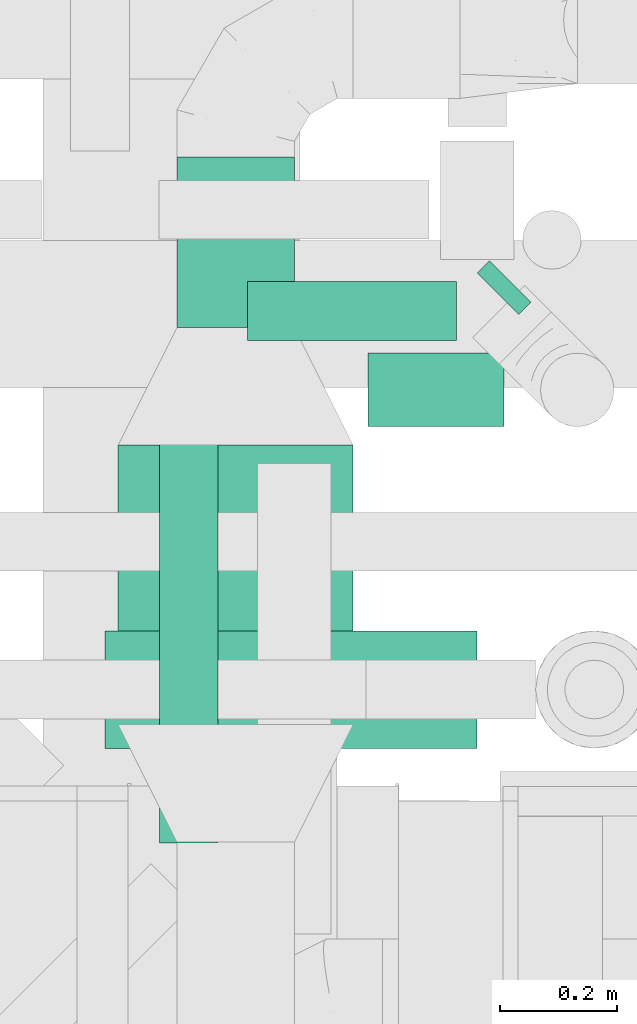
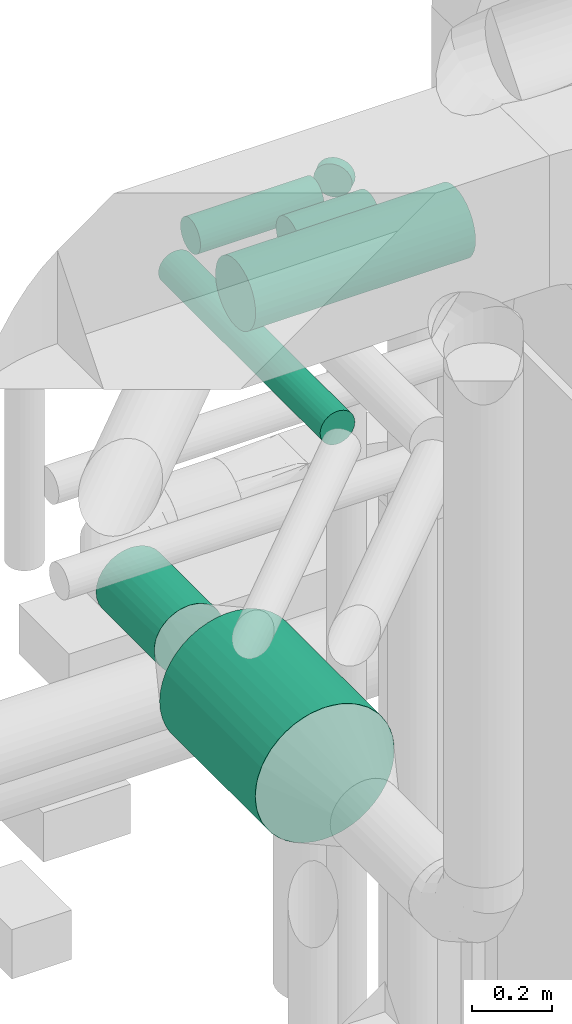
# One storey, part 249 of 337: 7 flow segments.
"""IFC2X3 building model written with IfcOpenShell, lengths in millimetres."""

from ifc_helpers import new_model, entity, si_unit, converted_unit, derived_unit, direction, frame, origin, origin_2d_with_axis, place, context, subcontext, project, spatial, circle, extrude, type_object, element, save


model = new_model("IFC2X3")

# Units and contexts
model_context = context("Model", 3, precision=0.01, world=origin(), true_north=direction((6.12303176911189e-17, 1.0)))
body_context = subcontext(model_context, "Body", "Model", "MODEL_VIEW")
ifc_project = project(units=[si_unit("LENGTHUNIT", "METRE", prefix="MILLI"), si_unit("AREAUNIT", "SQUARE_METRE"), si_unit("VOLUMEUNIT", "CUBIC_METRE"), converted_unit("PLANEANGLEUNIT", "DEGREE", entity("IfcRatioMeasure", 0.0174532925199433), si_unit("PLANEANGLEUNIT", "RADIAN"), dimensions=[0, 0, 0, 0, 0, 0, 0]), si_unit("MASSUNIT", "GRAM", prefix="KILO"), derived_unit("MASSDENSITYUNIT", [(si_unit("MASSUNIT", "GRAM", prefix="KILO"), 1), (si_unit("LENGTHUNIT", "METRE"), -3)]), derived_unit("MOMENTOFINERTIAUNIT", [(si_unit("LENGTHUNIT", "METRE"), 4)]), si_unit("TIMEUNIT", "SECOND"), si_unit("FREQUENCYUNIT", "HERTZ"), si_unit("THERMODYNAMICTEMPERATUREUNIT", "DEGREE_CELSIUS"), derived_unit("THERMALTRANSMITTANCEUNIT", [(si_unit("MASSUNIT", "GRAM", prefix="KILO"), 1), (si_unit("THERMODYNAMICTEMPERATUREUNIT", "KELVIN"), -1), (si_unit("TIMEUNIT", "SECOND"), -3)]), derived_unit("VOLUMETRICFLOWRATEUNIT", [(si_unit("LENGTHUNIT", "METRE"), 3), (si_unit("TIMEUNIT", "SECOND"), -1)]), derived_unit("MASSFLOWRATEUNIT", [(si_unit("MASSUNIT", "GRAM", prefix="KILO"), 1), (si_unit("TIMEUNIT", "SECOND"), -1)]), derived_unit("ROTATIONALFREQUENCYUNIT", [(si_unit("TIMEUNIT", "SECOND"), -1)]), si_unit("ELECTRICCURRENTUNIT", "AMPERE"), si_unit("ELECTRICVOLTAGEUNIT", "VOLT"), si_unit("POWERUNIT", "WATT"), si_unit("FORCEUNIT", "NEWTON", prefix="KILO"), si_unit("ILLUMINANCEUNIT", "LUX"), si_unit("LUMINOUSFLUXUNIT", "LUMEN"), si_unit("LUMINOUSINTENSITYUNIT", "CANDELA"), derived_unit("USERDEFINED", [(si_unit("MASSUNIT", "GRAM", prefix="KILO"), -1), (si_unit("LENGTHUNIT", "METRE"), -2), (si_unit("TIMEUNIT", "SECOND"), 3), (si_unit("LUMINOUSFLUXUNIT", "LUMEN"), 1)]), derived_unit("LINEARVELOCITYUNIT", [(si_unit("LENGTHUNIT", "METRE"), 1), (si_unit("TIMEUNIT", "SECOND"), -1)]), si_unit("PRESSUREUNIT", "PASCAL"), derived_unit("USERDEFINED", [(si_unit("LENGTHUNIT", "METRE"), -2), (si_unit("MASSUNIT", "GRAM", prefix="KILO"), 1), (si_unit("TIMEUNIT", "SECOND"), -2)]), derived_unit("LINEARFORCEUNIT", [(si_unit("MASSUNIT", "GRAM", prefix="KILO"), 1), (si_unit("LENGTHUNIT", "METRE"), 1), (si_unit("TIMEUNIT", "SECOND"), -2), (si_unit("LENGTHUNIT", "METRE"), -1)]), derived_unit("PLANARFORCEUNIT", [(si_unit("MASSUNIT", "GRAM", prefix="KILO"), 1), (si_unit("LENGTHUNIT", "METRE"), 1), (si_unit("TIMEUNIT", "SECOND"), -2), (si_unit("LENGTHUNIT", "METRE"), -2)])], contexts=[model_context])

# Site, building, storey
site_placement = place(None, origin())
site = spatial("IfcSite", under=ifc_project, at=site_placement, CompositionType="ELEMENT")
building_placement = place(site_placement, origin())
building = spatial("IfcBuilding", under=site, at=building_placement, CompositionType="ELEMENT")
storey_placement = place(building_placement, origin())
storey = spatial("IfcBuildingStorey", under=building, at=storey_placement, CompositionType="ELEMENT", Elevation=0.0)

# Flow segments
duct_segment_type = type_object("IfcDuctSegmentType", PredefinedType="NOTDEFINED")
flow_segment_1_placement = place(storey_placement, frame((58173.85, 11593.18, 30448.4)))
element("IfcFlowSegment", 1, at=flow_segment_1_placement, inside=storey, type_object=duct_segment_type, context=body_context, shape_type="SweptSolid", body=[
    extrude(circle(Radius=50.0, at=origin_2d_with_axis()), frame((51.6, 0.0, 51.6), z_axis=(0.0, 1.0, 0.0), x_axis=(1.0, 0.0, 0.0)), (0.0, 0.0, 1.0), 805.319830735413),
])
flow_segment_2_placement = place(storey_placement, frame((58325.44, 12446.9, 30448.4)))
element("IfcFlowSegment", 2, at=flow_segment_2_placement, inside=storey, type_object=duct_segment_type, context=body_context, shape_type="SweptSolid", body=[
    extrude(circle(Radius=50.0, at=origin_2d_with_axis()), frame((0.0, 51.6, 51.6), z_axis=(1.0, 0.0, 0.0), x_axis=(0.0, -1.0, 0.0)), (0.0, 0.0, 1.0), 355.473090735392),
])
flow_segment_3_placement = place(storey_placement, frame((58714.68, 12490.84, 30448.4)))
element("IfcFlowSegment", 3, at=flow_segment_3_placement, inside=storey, type_object=duct_segment_type, context=body_context, shape_type="SweptSolid", body=[
    extrude(circle(Radius=50.0, at=origin_2d_with_axis()), frame((36.95, 36.95, 51.6), z_axis=(0.707106781186548, 0.707106781186548, 0.0), x_axis=(0.707106781186548, -0.707106781186548, 0.0)), (0.0, 0.0, 1.0), 30.0134160280934),
])
flow_segment_4_placement = place(storey_placement, frame((58530.03, 12300.23, 30433.4)))
element("IfcFlowSegment", 4, at=flow_segment_4_placement, inside=storey, type_object=duct_segment_type, context=body_context, shape_type="SweptSolid", body=[
    extrude(circle(Radius=62.5, at=origin_2d_with_axis()), frame((0.0, 64.1, 64.1), z_axis=(1.0, 0.0, 0.0), x_axis=(0.0, -1.0, 0.0)), (0.0, 0.0, 1.0), 231.597169999976),
])
flow_segment_5_placement = place(storey_placement, frame((58203.44, 12470.26, 29198.4)))
element("IfcFlowSegment", 5, at=flow_segment_5_placement, inside=storey, type_object=duct_segment_type, context=body_context, shape_type="SweptSolid", body=[
    extrude(circle(Radius=100.0, at=origin_2d_with_axis()), frame((101.6, 0.0, 101.6), z_axis=(0.0, 1.0, 0.0), x_axis=(-1.0, 0.0, 0.0)), (0.0, 0.0, 1.0), 290.318488984484),
])
flow_segment_6_placement = place(storey_placement, frame((58103.44, 11794.26, 29098.4)))
element("IfcFlowSegment", 6, at=flow_segment_6_placement, inside=storey, type_object=duct_segment_type, context=body_context, shape_type="SweptSolid", body=[
    extrude(circle(Radius=200.0, at=origin_2d_with_axis()), frame((201.6, 0.0, 201.6), z_axis=(0.0, 1.0, 0.0), x_axis=(-1.0, 0.0, 0.0)), (0.0, 0.0, 1.0), 475.999999999998),
])
flow_segment_7_placement = place(storey_placement, frame((58083.01, 11752.63, 30698.4)))
element("IfcFlowSegment", 7, at=flow_segment_7_placement, inside=storey, type_object=duct_segment_type, context=body_context, shape_type="SweptSolid", body=[
    extrude(circle(Radius=100.0, at=origin_2d_with_axis()), frame((0.0, 101.6, 101.6), z_axis=(1.0, 0.0, 0.0), x_axis=(0.0, -1.0, 0.0)), (0.0, 0.0, 1.0), 632.624325282615),
])

save(model, "model.ifc")
